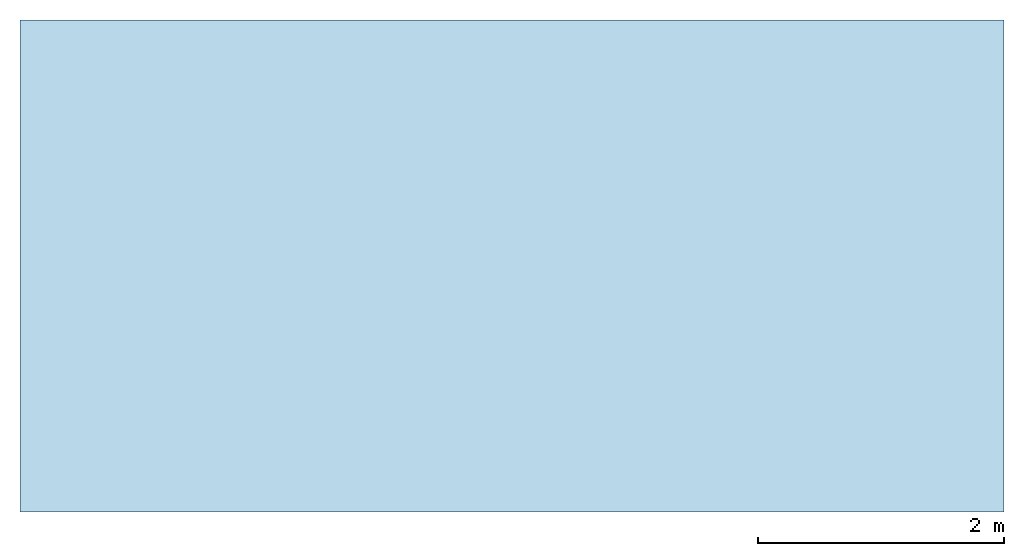
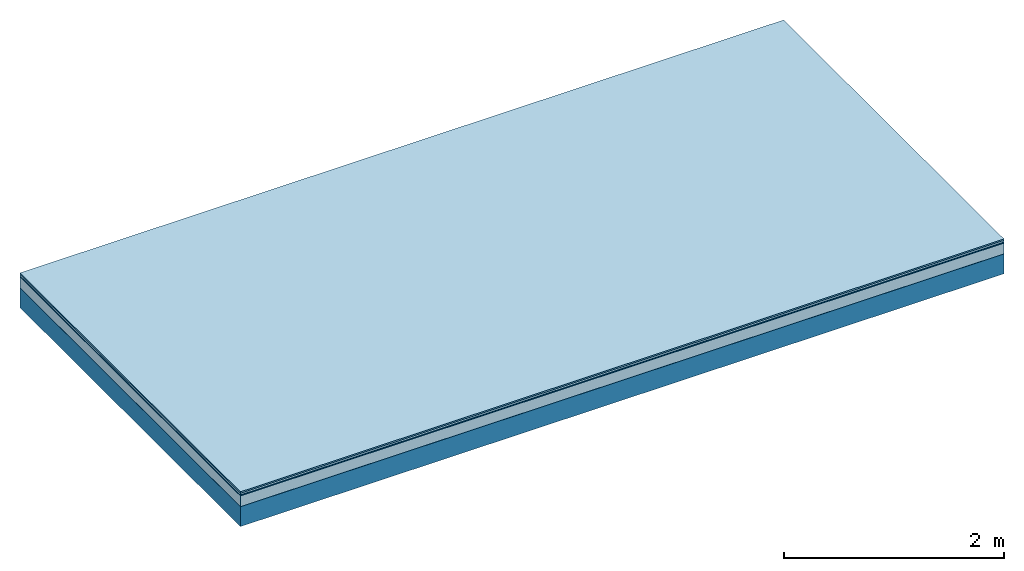
# One storey: 5 plates, 1 member, 1 element without a shape of its own.
"""IFC4 building model written with IfcOpenShell, lengths in metres."""

from ifc_helpers import new_model, si_unit, derived_unit, direction, frame, frame_2d, origin, origin_with_axes, place, context, project, spatial, rectangle, extrude, material, layer, layer_set, type_object, element, aggregate, save


model = new_model("IFC4")

# Units and contexts
plan_context = context("Plan", 3, precision=1e-05, world=origin(), true_north=direction((0.0, 1.0)))
model_context = context("Model", 3, precision=1e-05, world=origin(), true_north=direction((0.0, 1.0)))
ifc_project = project(units=[si_unit("LENGTHUNIT", "METRE"), derived_unit("SOUNDPRESSUREUNIT", [(si_unit("PRESSUREUNIT", "PASCAL", prefix="MICRO"), 0)]), si_unit("ENERGYUNIT", "JOULE", prefix="MEGA"), si_unit("MASSUNIT", "GRAM", prefix="KILO"), derived_unit("THERMALTRANSMITTANCEUNIT", [(si_unit("POWERUNIT", "WATT"), 1), (si_unit("AREAUNIT", "SQUARE_METRE"), -1), (si_unit("THERMODYNAMICTEMPERATUREUNIT", "KELVIN"), -1)]), derived_unit("AREADENSITYUNIT", [(si_unit("MASSUNIT", "GRAM", prefix="KILO"), 1), (si_unit("AREAUNIT", "SQUARE_METRE"), -1)]), derived_unit("USERDEFINED", [(si_unit("ENERGYUNIT", "JOULE", prefix="MEGA"), 1), (si_unit("AREAUNIT", "SQUARE_METRE"), -1)])], contexts=[plan_context, model_context])

# Site, building, storey
site = spatial("IfcSite", under=ifc_project)
building_placement = place(None, origin())
building = spatial("IfcBuilding", under=site, at=building_placement)
storey_placement = place(building_placement, origin())
storey = spatial("IfcBuildingStorey", under=building, at=storey_placement)

# Slab, member, plates
ifc_material_1 = material(Category="11.013")
ifc_layer_1 = layer(ifc_material_1, 0.015, Name="Flooring")
ifc_material_2 = material(Category="03.007")
ifc_layer_2 = layer(ifc_material_2, 0.02, Name="On-material")
ifc_material_3 = material(Name="Wood fiber generic product", Category="10.009")
ifc_layer_3 = layer(ifc_material_3, 0.01, Name="Impact sound insulation")
ifc_material_4 = material(Category="03.011")
ifc_layer_4 = layer(ifc_material_4, 0.12, Name="on Supporting structure")
ifc_material_5 = material(Name="protection", Category="09.007")
ifc_layer_5 = layer(ifc_material_5, 0.0005, Name="Sub-floor")
ifc_material_6 = material(Name="no composite action")
ifc_layer_6 = layer(ifc_material_6, 0.0, Name="Bond")
ifc_layer_7 = layer(None, 0.22, Name="Supporting structure")
ifc_layer_set = layer_set([ifc_layer_1, ifc_layer_2, ifc_layer_3, ifc_layer_4, ifc_layer_5, ifc_layer_6, ifc_layer_7])
slab_type = type_object("IfcSlabType", Name="A2056", PredefinedType="NOTDEFINED", material=ifc_layer_set)
slab_placement = place(None, frame((0.0, 0.0, 0.0), z_axis=(0.0, 0.0, -1.0), x_axis=(1.0, 0.0, 0.0)))
slab = element("IfcSlab", 1, at=slab_placement, inside=storey, type_object=slab_type, material=ifc_layer_set, Name="Slab #1")
ifc_material_7 = material(Name="Solid timber panel")
member_placement = place(slab_placement, origin())
member = element("IfcMember", 2, at=member_placement, material=ifc_material_7, Name="Supporting structure", context=plan_context, shape_type="SweptSolid", body=[
    extrude(rectangle(XDim=1.0, YDim=0.22, at=frame_2d((0.5, 0.11), x_axis=(1.0, 0.0))), frame((0.0, 4.0, 0.1655), z_axis=(0.0, -1.0, 0.0), x_axis=(1.0, 0.0, 0.0)), (0.0, 0.0, 1.0), 4.0),
    extrude(rectangle(XDim=1.0, YDim=0.22, at=frame_2d((0.5, 0.11), x_axis=(1.0, 0.0))), frame((1.0, 4.0, 0.1655), z_axis=(0.0, -1.0, 0.0), x_axis=(1.0, 0.0, 0.0)), (0.0, 0.0, 1.0), 4.0),
    extrude(rectangle(XDim=1.0, YDim=0.22, at=frame_2d((0.5, 0.11), x_axis=(1.0, 0.0))), frame((2.0, 4.0, 0.1655), z_axis=(0.0, -1.0, 0.0), x_axis=(1.0, 0.0, 0.0)), (0.0, 0.0, 1.0), 4.0),
    extrude(rectangle(XDim=1.0, YDim=0.22, at=frame_2d((0.5, 0.11), x_axis=(1.0, 0.0))), frame((3.0, 4.0, 0.1655), z_axis=(0.0, -1.0, 0.0), x_axis=(1.0, 0.0, 0.0)), (0.0, 0.0, 1.0), 4.0),
    extrude(rectangle(XDim=1.0, YDim=0.22, at=frame_2d((0.5, 0.11), x_axis=(1.0, 0.0))), frame((4.0, 4.0, 0.1655), z_axis=(0.0, -1.0, 0.0), x_axis=(1.0, 0.0, 0.0)), (0.0, 0.0, 1.0), 4.0),
    extrude(rectangle(XDim=1.0, YDim=0.22, at=frame_2d((0.5, 0.11), x_axis=(1.0, 0.0))), frame((5.0, 4.0, 0.1655), z_axis=(0.0, -1.0, 0.0), x_axis=(1.0, 0.0, 0.0)), (0.0, 0.0, 1.0), 4.0),
    extrude(rectangle(XDim=1.0, YDim=0.22, at=frame_2d((0.5, 0.11), x_axis=(1.0, 0.0))), frame((6.0, 4.0, 0.1655), z_axis=(0.0, -1.0, 0.0), x_axis=(1.0, 0.0, 0.0)), (0.0, 0.0, 1.0), 4.0),
    extrude(rectangle(XDim=1.0, YDim=0.22, at=frame_2d((0.5, 0.11), x_axis=(1.0, 0.0))), frame((7.0, 4.0, 0.1655), z_axis=(0.0, -1.0, 0.0), x_axis=(1.0, 0.0, 0.0)), (0.0, 0.0, 1.0), 4.0),
])
plate_1_placement = place(slab_placement, origin())
plate_1 = element("IfcPlate", 3, at=plate_1_placement, material=ifc_material_1, Name="Flooring", context=plan_context, shape_type="SweptSolid", body=[
    extrude(rectangle(XDim=8.0, YDim=4.0, at=frame_2d((4.0, 2.0), x_axis=(1.0, 0.0))), origin_with_axes(), (0.0, 0.0, 1.0), 0.015),
])
plate_2_placement = place(slab_placement, origin())
plate_2 = element("IfcPlate", 4, at=plate_2_placement, material=ifc_material_2, Name="On-material", context=plan_context, shape_type="SweptSolid", body=[
    extrude(rectangle(XDim=8.0, YDim=4.0, at=frame_2d((4.0, 2.0), x_axis=(1.0, 0.0))), frame((0.0, 0.0, 0.015), z_axis=(0.0, 0.0, 1.0), x_axis=(1.0, 0.0, 0.0)), (0.0, 0.0, 1.0), 0.02),
])
plate_3_placement = place(slab_placement, origin())
plate_3 = element("IfcPlate", 5, at=plate_3_placement, material=ifc_material_3, Name="Impact sound insulation", context=plan_context, shape_type="SweptSolid", body=[
    extrude(rectangle(XDim=8.0, YDim=4.0, at=frame_2d((4.0, 2.0), x_axis=(1.0, 0.0))), frame((0.0, 0.0, 0.035), z_axis=(0.0, 0.0, 1.0), x_axis=(1.0, 0.0, 0.0)), (0.0, 0.0, 1.0), 0.01),
])
plate_4_placement = place(slab_placement, origin())
plate_4 = element("IfcPlate", 6, at=plate_4_placement, material=ifc_material_4, Name="on Supporting structure", context=plan_context, shape_type="SweptSolid", body=[
    extrude(rectangle(XDim=8.0, YDim=4.0, at=frame_2d((4.0, 2.0), x_axis=(1.0, 0.0))), frame((0.0, 0.0, 0.045), z_axis=(0.0, 0.0, 1.0), x_axis=(1.0, 0.0, 0.0)), (0.0, 0.0, 1.0), 0.12),
])
plate_5_placement = place(slab_placement, origin())
plate_5 = element("IfcPlate", 7, at=plate_5_placement, material=ifc_material_5, Name="Sub-floor", context=plan_context, shape_type="SweptSolid", body=[
    extrude(rectangle(XDim=8.0, YDim=4.0, at=frame_2d((4.0, 2.0), x_axis=(1.0, 0.0))), frame((0.0, 0.0, 0.165), z_axis=(0.0, 0.0, 1.0), x_axis=(1.0, 0.0, 0.0)), (0.0, 0.0, 1.0), 0.0005),
])
aggregate(slab, [plate_1, plate_2, plate_3, plate_4, plate_5, member])

save(model, "model.ifc")
